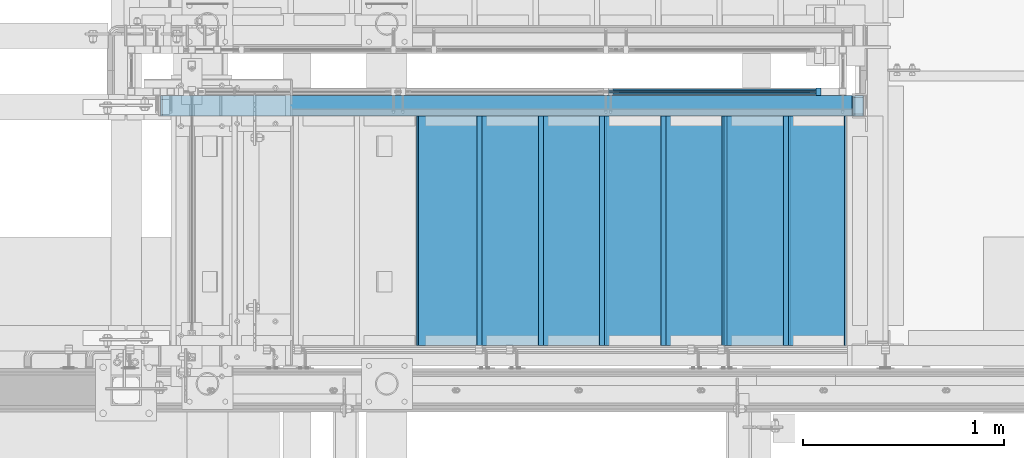
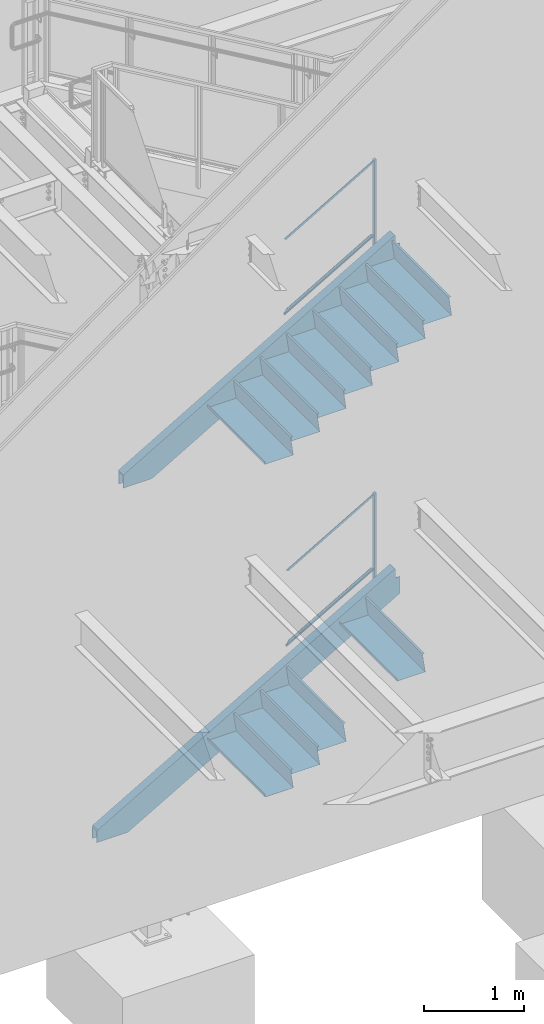
# One storey, part 784 of 1179: 15 beams, 6 members, 4 elements without a shape of their own.
"""IFC2X3 building model written with IfcOpenShell, lengths in millimetres."""

from ifc_helpers import new_model, si_unit, frame, origin_with_axes, place, context, subcontext, project, spatial, faceted_brep, material, type_object, element, aggregate, save


model = new_model("IFC2X3")

# Units and contexts
model_context = context("Model", 3, precision=1e-05, world=origin_with_axes())
body_context = subcontext(model_context, "Body", "Model", "MODEL_VIEW")
ifc_project = project(units=[si_unit("LENGTHUNIT", "METRE", prefix="MILLI"), si_unit("AREAUNIT", "SQUARE_METRE"), si_unit("VOLUMEUNIT", "CUBIC_METRE"), si_unit("MASSUNIT", "GRAM", prefix="KILO"), si_unit("TIMEUNIT", "SECOND"), si_unit("PLANEANGLEUNIT", "RADIAN"), si_unit("SOLIDANGLEUNIT", "STERADIAN"), si_unit("THERMODYNAMICTEMPERATUREUNIT", "DEGREE_CELSIUS"), si_unit("LUMINOUSINTENSITYUNIT", "LUMEN")], contexts=[model_context])

# Site, building, storey
site_placement = place(None, origin_with_axes())
site = spatial("IfcSite", under=ifc_project, at=site_placement, CompositionType="ELEMENT")
building_placement = place(site_placement, origin_with_axes())
building = spatial("IfcBuilding", under=site, at=building_placement, Name="Undefined", CompositionType="ELEMENT")
storey_placement = place(building_placement, origin_with_axes())
storey = spatial("IfcBuildingStorey", under=building, at=storey_placement, Name="Undefined", CompositionType="ELEMENT", Elevation=0.0)

# Assembly, member
assembly_1_placement = place(storey_placement, origin_with_axes())
assembly_1 = element("IfcElementAssembly", 1, at=assembly_1_placement, inside=storey, Name="GUARDRAIL", AssemblyPlace="NOTDEFINED", PredefinedType="RIGID_FRAME")
ifc_material_1 = material(Name="STEEL/A36")
member_type_1 = type_object("IfcMemberType", PredefinedType="NOTDEFINED")
member_1_placement = place(assembly_1_placement, frame((22723.4750016698, 39471.5999992249, 5909.47487240477), z_axis=(0.0, -1.0, 0.0), x_axis=(0.0, 0.0, 1.0)))
member_1 = element("IfcMember", 2, at=member_1_placement, type_object=member_type_1, material=ifc_material_1, Name="POST", context=body_context, shape_type="Brep", body=[
    faceted_brep([(0.0, 12.7000000000007, -19.0500000000029), (0.0, 12.7000000000007, 19.0500000000029), (1243.17712591994, 12.7000000000007, 19.0500000000029), (1243.17712591994, 12.7000000000007, -19.0500000000029), (0.0, -12.7000000000007, 19.0500000000029), (1257.99379259886, -12.7000000000007, 19.0500000000029), (0.0, -12.7000000000007, -19.0500000000029), (1257.99379259886, -12.7000000000007, -19.0500000000029)], [[[0, 1, 2, 3]], [[1, 4, 5, 2]], [[4, 6, 7, 5]], [[6, 0, 3, 7]], [[5, 7, 3, 2]], [[6, 4, 1, 0]]]),
])

assembly_2_placement = place(storey_placement, origin_with_axes())
assembly_2 = element("IfcElementAssembly", 3, at=assembly_2_placement, inside=storey, Name="GUARDRAIL", AssemblyPlace="NOTDEFINED", PredefinedType="RIGID_FRAME")
member_2_placement = place(assembly_2_placement, frame((22723.4748880622, 39471.5999999818, 1836.90255809336), z_axis=(0.0, -1.0, 0.0), x_axis=(0.0, 0.0, 1.0)))
member_2 = element("IfcMember", 4, at=member_2_placement, type_object=member_type_1, material=ifc_material_1, Name="POST", context=body_context, shape_type="Brep", body=[
    faceted_brep([(0.0, 12.7000000000007, -19.0500000000029), (0.0, 12.7000000000007, 19.0500000000029), (1242.88603593101, 12.7000000000007, 19.0500000000029), (1242.88603593101, 12.7000000000007, -19.0500000000029), (0.0, -12.7000000000007, 19.0500000000029), (1257.59245954642, -12.7000000000007, 19.0500000000029), (0.0, -12.7000000000007, -19.0500000000029), (1257.59245954642, -12.7000000000007, -19.0500000000029)], [[[0, 1, 2, 3]], [[1, 4, 5, 2]], [[4, 6, 7, 5]], [[6, 0, 3, 7]], [[5, 7, 3, 2]], [[6, 4, 1, 0]]]),
])

# Beam
ifc_material_2 = material(Name="STEEL/BUY-OUT")
beam_type_1 = type_object("IfcBeamType", PredefinedType="NOTDEFINED")
beam_1_placement = place(assembly_1_placement, frame((22207.4247953794, 39468.4251646336, 6827.78756354688), z_axis=(-0.86377890071706, 0.0, -0.503871025835012), x_axis=(-0.503871025835012, 0.0, 0.86377890071706)))
beam_1 = element("IfcBeam", 5, at=beam_1_placement, type_object=beam_type_1, material=ifc_material_2, Name="U-EDGE", context=body_context, shape_type="Brep", body=[
    faceted_brep([(-2.62571120401844e-09, 1.58750000000146, -551.090159790514), (22.2250002407682, 1.58750000000146, -589.784707497234), (22.2250002534201, 4.76249998393178, -589.784707519266), (5.1261577027617e-07, 4.76249998815911, -551.090160687567), (5.1261577027617e-07, 7.93749998815474, -551.090160687567), (25.400000253393, 7.93749998378189, -595.312499999403), (25.4000002406228, -1.58750000000146, -595.312499999232), (-2.62571120401844e-09, -1.58750000000146, -551.090159790514), (25.4000002718667, -1.58750000000146, 595.312499998905), (2.76122591458261e-09, -1.58750000000146, 580.723427522342), (2.76122591458261e-09, 1.58750000000146, 580.723427522342), (22.2250002718201, 1.58750000000146, 593.488867387849), (22.2250002590899, 4.76250001617154, 593.48886738054), (5.1151801017113e-07, 4.76250001247536, 580.723427814559), (5.1151801017113e-07, 7.93750001247827, 580.723427814559), (25.4000002590974, 7.93750001621811, 595.31249999873)], [[[0, 1, 2, 3, 4, 5, 6, 7]], [[7, 6, 8, 9]], [[0, 7, 9, 10]], [[1, 0, 10, 11]], [[2, 1, 11, 12]], [[3, 2, 12, 13]], [[4, 3, 13, 14]], [[5, 4, 14, 15]], [[6, 5, 15, 8]], [[14, 13, 12, 11, 10, 9, 8, 15]]]),
])

beam_2_placement = place(assembly_1_placement, frame((22181.828174335, 39468.4251646336, 5963.61748034283), z_axis=(-0.86377890071706, 0.0, -0.503871025835012), x_axis=(0.503871110270223, 0.0, -0.863778851463181)))
beam_2 = element("IfcBeam", 6, at=beam_2_placement, type_object=beam_type_1, material=ifc_material_2, Name="U-EDGE", context=body_context, shape_type="Brep", body=[
    faceted_brep([(3.39150574291125e-09, 1.58750000000146, 551.090060740255), (3.39150574291125e-09, -1.58750000000146, 551.090060740255), (22.2249999259266, -1.58750000000146, 589.784086195607), (22.2249999386131, -4.76249998396088, 589.784086217693), (-1.22384335554671e-07, -4.76249998815911, 551.090060521277), (-1.22384335554671e-07, -7.93749998815474, 551.090060521277), (25.3999999386497, -7.93749998381099, 595.312500000691), (25.3999999258431, 1.58750000000146, 595.31250000052), (25.3999999312882, -7.93750001618173, -595.312500000728), (25.3999999440939, 1.58750000000146, -595.312500000899), (-3.57522367266938e-09, 1.58750000000146, -580.72370144297), (-3.57522367266938e-09, -1.58750000000146, -580.72370144297), (22.2249999440628, -1.58750000000146, -593.488900187338), (22.2249999312971, -4.76250001613516, -593.488900180007), (-1.35833943204489e-07, -4.76250001247536, -580.723701367002), (-1.35833943204489e-07, -7.93750001247827, -580.723701367002)], [[[0, 1, 2, 3, 4, 5, 6, 7]], [[7, 6, 8, 9]], [[0, 7, 9, 10]], [[1, 0, 10, 11]], [[2, 1, 11, 12]], [[3, 2, 12, 13]], [[4, 3, 13, 14]], [[5, 4, 14, 15]], [[6, 5, 15, 8]], [[14, 13, 12, 11, 10, 9, 8, 15]]]),
])

beam_3_placement = place(assembly_2_placement, frame((22219.0901164369, 39468.4251653905, 2763.9218515972), z_axis=(-0.86540914081269, 0.0, -0.501065882891503), x_axis=(-0.501065882891504, 0.0, 0.86540914081269)))
beam_3 = element("IfcBeam", 7, at=beam_3_placement, type_object=beam_type_1, material=ifc_material_2, Name="U-EDGE", context=body_context, shape_type="Brep", body=[
    faceted_brep([(5.01850081491284e-07, 7.93750000584987, 565.654393641868), (5.01850081491284e-07, 4.76250000584696, 565.654393641868), (22.2250002528726, 4.76250000758591, 578.467765219681), (22.2250002588062, 1.58750000000146, 578.467765223097), (1.87355908565223e-09, 1.58750000000146, 565.654393353612), (1.87355908565223e-09, -1.58750000000146, 565.654393353612), (25.4000002588291, -1.58750000000146, 580.298246897597), (25.4000002528755, 7.93750000761065, 580.298246894159), (25.4000002430021, -1.58750000000146, -581.025000000453), (25.4000002489647, 7.9374999923748, -581.025000000533), (5.01226168125868e-07, 7.93749999444117, -536.968296245806), (5.01226168125868e-07, 4.76249999444553, -536.968296245806), (22.2250002489855, 4.76249999245192, -575.517911967814), (22.225000243081, 1.58750000000146, -575.51791195757), (-1.78260961547494e-09, 1.58750000000146, -536.968295373328), (-1.78260961547494e-09, -1.58750000000146, -536.968295373328)], [[[0, 1, 2, 3, 4, 5, 6, 7]], [[7, 6, 8, 9]], [[0, 7, 9, 10]], [[1, 0, 10, 11]], [[2, 1, 11, 12]], [[3, 2, 12, 13]], [[4, 3, 13, 14]], [[5, 4, 14, 15]], [[6, 5, 15, 8]], [[14, 13, 12, 11, 10, 9, 8, 15]]]),
])

beam_4_placement = place(assembly_2_placement, frame((22193.6359371502, 39468.4251653905, 1898.85141215456), z_axis=(-0.86540914081269, 0.0, -0.501065882891503), x_axis=(0.501065782098943, 0.0, -0.865409199170875)))
beam_4 = element("IfcBeam", 8, at=beam_4_placement, type_object=beam_type_1, material=ifc_material_2, Name="U-EDGE", context=body_context, shape_type="Brep", body=[
    faceted_brep([(-3.45607986673713e-10, 1.58750000000146, 536.241472034682), (-3.45607986673713e-10, -1.58750000000146, 536.241472034682), (22.2250001997436, -1.58750000000146, 574.791082474552), (22.2250002132259, -4.76249998287676, 574.791082497944), (4.30125510320067e-07, -4.76249998738058, 536.241472781338), (4.30125510320067e-07, -7.93749998737621, 536.241472781338), (25.400000213227, -7.93749998271232, 580.298169654056), (25.4000001996137, 1.58750000000146, 580.298169630441), (25.4000002140147, -7.93750001730223, -581.024999999514), (25.4000002276443, 1.58750000000146, -581.0249999997), (3.69254848919809e-10, 1.58750000000146, -566.38114146873), (3.69254848919809e-10, -1.58750000000146, -566.38114146873), (22.2250002275978, -1.58750000000146, -579.194516836025), (22.2250002140099, -4.76250001724839, -579.194516828193), (4.23933670390397e-07, -4.76250001332664, -566.381141712925), (4.23933670390397e-07, -7.93750001332955, -566.381141712925)], [[[0, 1, 2, 3, 4, 5, 6, 7]], [[7, 6, 8, 9]], [[0, 7, 9, 10]], [[1, 0, 10, 11]], [[2, 1, 11, 12]], [[3, 2, 12, 13]], [[4, 3, 13, 14]], [[5, 4, 14, 15]], [[6, 5, 15, 8]], [[14, 13, 12, 11, 10, 9, 8, 15]]]),
])

# Member
member_type_2 = type_object("IfcMemberType", PredefinedType="NOTDEFINED")
member_3_placement = place(assembly_1_placement, frame((21666.2000003427, 39471.5999992249, 5623.54470008453), z_axis=(0.0, -1.0, 0.0), x_axis=(0.863779574529786, 0.0, 0.503869870725709)))
member_3 = element("IfcMember", 9, at=member_3_placement, type_object=member_type_2, material=ifc_material_1, Name="BOTTOM_RAIL", context=body_context, shape_type="Brep", body=[
    faceted_brep([(1213.01152042107, 6.34999999947649, 12.6999999999971), (1205.60320984404, -6.35000000051605, 12.6999999999971), (1205.60320984404, -6.35000000051605, -12.6999999999971), (1213.01152042107, 6.34999999947649, -12.6999999999971), (18.4069803798266, 6.34999999998945, 12.6999999999971), (18.4069803798266, 6.34999999998945, -12.6999999999971), (10.9986698027969, -6.35000000000309, -12.6999999999971), (10.9986698027969, -6.35000000000309, 12.6999999999971)], [[[0, 1, 2, 3]], [[4, 5, 6, 7]], [[5, 4, 0, 3]], [[6, 5, 3, 2]], [[7, 6, 2, 1]], [[4, 7, 1, 0]]]),
])

aggregate(assembly_1, [beam_1, beam_2, member_3, member_1])

member_4_placement = place(assembly_2_placement, frame((21689.4832589038, 39471.5999999818, 1568.41922878821), z_axis=(0.0, -1.0, 0.0), x_axis=(0.86540914081267, 0.0, 0.501065882891537)))
member_4 = element("IfcMember", 10, at=member_4_placement, type_object=member_type_2, material=ifc_material_1, Name="BOTTOM_RAIL", context=body_context, shape_type="Brep", body=[
    faceted_brep([(1183.80237647433, 6.34999999946194, 12.6999999999971), (1176.44916466662, -6.35000000052969, 12.6999999999971), (1176.44916466662, -6.35000000052969, -12.6999999999971), (1183.80237647433, 6.34999999946194, -12.6999999999971), (18.3517455546971, 6.34999999998763, 12.6999999999971), (18.3517455546971, 6.34999999998763, -12.6999999999971), (10.9985337469952, -6.35000000000582, -12.6999999999971), (10.9985337469952, -6.35000000000582, 12.6999999999971)], [[[0, 1, 2, 3]], [[4, 5, 6, 7]], [[5, 4, 0, 3]], [[6, 5, 3, 2]], [[7, 6, 2, 1]], [[4, 7, 1, 0]]]),
])

aggregate(assembly_2, [member_4, beam_3, beam_4, member_2])

# Assembly, beams
assembly_3_placement = place(storey_placement, origin_with_axes())
assembly_3 = element("IfcElementAssembly", 11, at=assembly_3_placement, inside=storey, Name="STAIR", AssemblyPlace="NOTDEFINED", PredefinedType="RIGID_FRAME")
beam_type_2 = type_object("IfcBeamType", PredefinedType="NOTDEFINED")
beam_5_placement = place(assembly_3_placement, frame((22879.0499999978, 38779.4500001282, 6189.96000000019), z_axis=(0.0, -1.0, 0.0), x_axis=(-1.0, 0.0, 0.0)))
beam_5 = element("IfcBeam", 12, at=beam_5_placement, type_object=beam_type_2, material=ifc_material_1, Name="TREAD", context=body_context, shape_type="Brep", body=[
    faceted_brep([(0.0, -1.28999999999996, -571.5), (0.0, -1.28999999999996, 571.5), (0.0, 1.28999999999996, 571.5), (0.0, 1.28999999999996, -571.5), (22.4252350064853, 1.28999999999996, 571.5), (22.4252350064853, 1.28999999999996, -571.5), (25.4000000000015, -1.28999999999996, -571.5), (25.4000000000015, -1.28999999999996, 571.5), (-10.2319078506589, 229.89, 571.5), (-10.2319078506589, 229.89, -571.5), (-7.25714285714275, 227.31, -571.5), (-7.25714285714275, 227.31, 571.5), (319.968697988821, 229.89, 571.5), (319.968697988821, 229.89, -571.5), (317.731075852447, 227.31, -571.5), (317.731075852447, 227.31, 571.5), (325.673299218732, 189.957791390602, 571.5), (325.673299218732, 189.957791390602, -571.5), (323.119229525088, 189.592924291511, 571.5), (323.119229525088, 189.592924291511, -571.5)], [[[0, 1, 2, 3]], [[3, 2, 4, 5]], [[1, 0, 6, 7]], [[5, 4, 8, 9]], [[7, 6, 10, 11]], [[9, 8, 12, 13]], [[11, 10, 14, 15]], [[13, 12, 16, 17]], [[12, 8, 4, 2, 1, 7, 11, 15, 18, 16]], [[15, 14, 19, 18]], [[14, 10, 6, 0, 3, 5, 9, 13, 17, 19]], [[18, 19, 17, 16]]]),
])
beam_6_placement = place(assembly_3_placement, frame((22574.2500000208, 38779.4500001282, 6012.16000000019), z_axis=(0.0, -1.0, 0.0), x_axis=(-1.0, 0.0, 0.0)))
beam_6 = element("IfcBeam", 13, at=beam_6_placement, type_object=beam_type_2, material=ifc_material_1, Name="TREAD", context=body_context, shape_type="Brep", body=[
    faceted_brep([(0.0, -1.28999999999996, -571.5), (0.0, -1.28999999999996, 571.5), (0.0, 1.28999999999996, 571.5), (0.0, 1.28999999999996, -571.5), (22.4252350064853, 1.28999999999996, 571.5), (22.4252350064853, 1.28999999999996, -571.5), (25.4000000000015, -1.28999999999996, -571.5), (25.4000000000015, -1.28999999999996, 571.5), (-10.2319078506589, 229.89, 571.5), (-10.2319078506589, 229.89, -571.5), (-7.25714285714275, 227.31, -571.5), (-7.25714285714275, 227.31, 571.5), (319.968697988821, 229.89, 571.5), (319.968697988821, 229.89, -571.5), (317.731075852447, 227.31, -571.5), (317.731075852447, 227.31, 571.5), (325.673299218732, 189.957791390602, 571.5), (325.673299218732, 189.957791390602, -571.5), (323.119229525088, 189.592924291511, 571.5), (323.119229525088, 189.592924291511, -571.5)], [[[0, 1, 2, 3]], [[3, 2, 4, 5]], [[1, 0, 6, 7]], [[5, 4, 8, 9]], [[7, 6, 10, 11]], [[9, 8, 12, 13]], [[11, 10, 14, 15]], [[13, 12, 16, 17]], [[12, 8, 4, 2, 1, 7, 11, 15, 18, 16]], [[15, 14, 19, 18]], [[14, 10, 6, 0, 3, 5, 9, 13, 17, 19]], [[18, 19, 17, 16]]]),
])
beam_7_placement = place(assembly_3_placement, frame((22269.4500000437, 38779.4500001282, 5834.36000000019), z_axis=(0.0, -1.0, 0.0), x_axis=(-1.0, 0.0, 0.0)))
beam_7 = element("IfcBeam", 14, at=beam_7_placement, type_object=beam_type_2, material=ifc_material_1, Name="TREAD", context=body_context, shape_type="Brep", body=[
    faceted_brep([(0.0, -1.28999999999996, -571.5), (0.0, -1.28999999999996, 571.5), (0.0, 1.28999999999996, 571.5), (0.0, 1.28999999999996, -571.5), (22.4252350064853, 1.28999999999996, 571.5), (22.4252350064853, 1.28999999999996, -571.5), (25.4000000000015, -1.28999999999996, -571.5), (25.4000000000015, -1.28999999999996, 571.5), (-10.2319078506589, 229.89, 571.5), (-10.2319078506589, 229.89, -571.5), (-7.25714285714275, 227.31, -571.5), (-7.25714285714275, 227.31, 571.5), (319.968697988821, 229.89, 571.5), (319.968697988821, 229.89, -571.5), (317.731075852447, 227.31, -571.5), (317.731075852447, 227.31, 571.5), (325.673299218732, 189.957791390602, 571.5), (325.673299218732, 189.957791390602, -571.5), (323.119229525088, 189.592924291511, 571.5), (323.119229525088, 189.592924291511, -571.5)], [[[0, 1, 2, 3]], [[3, 2, 4, 5]], [[1, 0, 6, 7]], [[5, 4, 8, 9]], [[7, 6, 10, 11]], [[9, 8, 12, 13]], [[11, 10, 14, 15]], [[13, 12, 16, 17]], [[12, 8, 4, 2, 1, 7, 11, 15, 18, 16]], [[15, 14, 19, 18]], [[14, 10, 6, 0, 3, 5, 9, 13, 17, 19]], [[18, 19, 17, 16]]]),
])
beam_8_placement = place(assembly_3_placement, frame((21964.6500000666, 38779.4500001282, 5656.56000000019), z_axis=(0.0, -1.0, 0.0), x_axis=(-1.0, 0.0, 0.0)))
beam_8 = element("IfcBeam", 15, at=beam_8_placement, type_object=beam_type_2, material=ifc_material_1, Name="TREAD", context=body_context, shape_type="Brep", body=[
    faceted_brep([(0.0, -1.28999999999996, -571.5), (0.0, -1.28999999999996, 571.5), (0.0, 1.28999999999996, 571.5), (0.0, 1.28999999999996, -571.5), (22.4252350064853, 1.28999999999996, 571.5), (22.4252350064853, 1.28999999999996, -571.5), (25.4000000000015, -1.28999999999996, -571.5), (25.4000000000015, -1.28999999999996, 571.5), (-10.2319078506589, 229.89, 571.5), (-10.2319078506589, 229.89, -571.5), (-7.25714285714275, 227.31, -571.5), (-7.25714285714275, 227.31, 571.5), (319.968697988821, 229.89, 571.5), (319.968697988821, 229.89, -571.5), (317.731075852447, 227.31, -571.5), (317.731075852447, 227.31, 571.5), (325.673299218732, 189.957791390602, 571.5), (325.673299218732, 189.957791390602, -571.5), (323.119229525088, 189.592924291511, 571.5), (323.119229525088, 189.592924291511, -571.5)], [[[0, 1, 2, 3]], [[3, 2, 4, 5]], [[1, 0, 6, 7]], [[5, 4, 8, 9]], [[7, 6, 10, 11]], [[9, 8, 12, 13]], [[11, 10, 14, 15]], [[13, 12, 16, 17]], [[12, 8, 4, 2, 1, 7, 11, 15, 18, 16]], [[15, 14, 19, 18]], [[14, 10, 6, 0, 3, 5, 9, 13, 17, 19]], [[18, 19, 17, 16]]]),
])
beam_9_placement = place(assembly_3_placement, frame((21659.8500000895, 38779.4500001282, 5478.76000000019), z_axis=(0.0, -1.0, 0.0), x_axis=(-1.0, 0.0, 0.0)))
beam_9 = element("IfcBeam", 16, at=beam_9_placement, type_object=beam_type_2, material=ifc_material_1, Name="TREAD", context=body_context, shape_type="Brep", body=[
    faceted_brep([(0.0, -1.28999999999996, -571.5), (0.0, -1.28999999999996, 571.5), (0.0, 1.28999999999996, 571.5), (0.0, 1.28999999999996, -571.5), (22.4252350064853, 1.28999999999996, 571.5), (22.4252350064853, 1.28999999999996, -571.5), (25.4000000000015, -1.28999999999996, -571.5), (25.4000000000015, -1.28999999999996, 571.5), (-10.2319078506589, 229.89, 571.5), (-10.2319078506589, 229.89, -571.5), (-7.25714285714275, 227.31, -571.5), (-7.25714285714275, 227.31, 571.5), (319.968697988821, 229.89, 571.5), (319.968697988821, 229.89, -571.5), (317.731075852447, 227.31, -571.5), (317.731075852447, 227.31, 571.5), (325.673299218732, 189.957791390602, 571.5), (325.673299218732, 189.957791390602, -571.5), (323.119229525088, 189.592924291511, 571.5), (323.119229525088, 189.592924291511, -571.5)], [[[0, 1, 2, 3]], [[3, 2, 4, 5]], [[1, 0, 6, 7]], [[5, 4, 8, 9]], [[7, 6, 10, 11]], [[9, 8, 12, 13]], [[11, 10, 14, 15]], [[13, 12, 16, 17]], [[12, 8, 4, 2, 1, 7, 11, 15, 18, 16]], [[15, 14, 19, 18]], [[14, 10, 6, 0, 3, 5, 9, 13, 17, 19]], [[18, 19, 17, 16]]]),
])
beam_10_placement = place(assembly_3_placement, frame((21355.0500001124, 38779.4500001282, 5300.96000000019), z_axis=(0.0, -1.0, 0.0), x_axis=(-1.0, 0.0, 0.0)))
beam_10 = element("IfcBeam", 17, at=beam_10_placement, type_object=beam_type_2, material=ifc_material_1, Name="TREAD", context=body_context, shape_type="Brep", body=[
    faceted_brep([(0.0, -1.28999999999996, -571.5), (0.0, -1.28999999999996, 571.5), (0.0, 1.28999999999996, 571.5), (0.0, 1.28999999999996, -571.5), (22.4252350064853, 1.28999999999996, 571.5), (22.4252350064853, 1.28999999999996, -571.5), (25.4000000000015, -1.28999999999996, -571.5), (25.4000000000015, -1.28999999999996, 571.5), (-10.2319078506589, 229.89, 571.5), (-10.2319078506589, 229.89, -571.5), (-7.25714285714275, 227.31, -571.5), (-7.25714285714275, 227.31, 571.5), (319.968697988821, 229.89, 571.5), (319.968697988821, 229.89, -571.5), (317.731075852447, 227.31, -571.5), (317.731075852447, 227.31, 571.5), (325.673299218732, 189.957791390602, 571.5), (325.673299218732, 189.957791390602, -571.5), (323.119229525088, 189.592924291511, 571.5), (323.119229525088, 189.592924291511, -571.5)], [[[0, 1, 2, 3]], [[3, 2, 4, 5]], [[1, 0, 6, 7]], [[5, 4, 8, 9]], [[7, 6, 10, 11]], [[9, 8, 12, 13]], [[11, 10, 14, 15]], [[13, 12, 16, 17]], [[12, 8, 4, 2, 1, 7, 11, 15, 18, 16]], [[15, 14, 19, 18]], [[14, 10, 6, 0, 3, 5, 9, 13, 17, 19]], [[18, 19, 17, 16]]]),
])
beam_11_placement = place(assembly_3_placement, frame((21050.2500001353, 38779.4500001282, 5123.16000000019), z_axis=(0.0, -1.0, 0.0), x_axis=(-1.0, 0.0, 0.0)))
beam_11 = element("IfcBeam", 18, at=beam_11_placement, type_object=beam_type_2, material=ifc_material_1, Name="TREAD", context=body_context, shape_type="Brep", body=[
    faceted_brep([(0.0, -1.28999999999996, -571.5), (0.0, -1.28999999999996, 571.5), (0.0, 1.28999999999996, 571.5), (0.0, 1.28999999999996, -571.5), (22.4252350064853, 1.28999999999996, 571.5), (22.4252350064853, 1.28999999999996, -571.5), (25.4000000000015, -1.28999999999996, -571.5), (25.4000000000015, -1.28999999999996, 571.5), (-10.2319078506589, 229.89, 571.5), (-10.2319078506589, 229.89, -571.5), (-7.25714285714275, 227.31, -571.5), (-7.25714285714275, 227.31, 571.5), (319.968697988821, 229.89, 571.5), (319.968697988821, 229.89, -571.5), (317.731075852447, 227.31, -571.5), (317.731075852447, 227.31, 571.5), (325.673299218732, 189.957791390602, 571.5), (325.673299218732, 189.957791390602, -571.5), (323.119229525088, 189.592924291511, 571.5), (323.119229525088, 189.592924291511, -571.5)], [[[0, 1, 2, 3]], [[3, 2, 4, 5]], [[1, 0, 6, 7]], [[5, 4, 8, 9]], [[7, 6, 10, 11]], [[9, 8, 12, 13]], [[11, 10, 14, 15]], [[13, 12, 16, 17]], [[12, 8, 4, 2, 1, 7, 11, 15, 18, 16]], [[15, 14, 19, 18]], [[14, 10, 6, 0, 3, 5, 9, 13, 17, 19]], [[18, 19, 17, 16]]]),
])

assembly_4_placement = place(storey_placement, origin_with_axes())
assembly_4 = element("IfcElementAssembly", 19, at=assembly_4_placement, inside=storey, Name="STAIR", AssemblyPlace="NOTDEFINED", PredefinedType="RIGID_FRAME")
beam_12_placement = place(assembly_4_placement, frame((22574.2500003809, 38779.4500000251, 1939.95791607597), z_axis=(0.0, -1.0, 0.0), x_axis=(-1.0, 0.0, 0.0)))
beam_12 = element("IfcBeam", 20, at=beam_12_placement, type_object=beam_type_2, material=ifc_material_1, Name="TREAD", context=body_context, shape_type="Brep", body=[
    faceted_brep([(0.0, -1.28999999999996, -571.5), (0.0, -1.28999999999996, 571.5), (0.0, 1.28999999999996, 571.5), (0.0, 1.28999999999996, -571.5), (22.4220799334253, 1.28999999999996, 571.5), (22.4220799334253, 1.28999999999996, -571.5), (25.4000000000015, -1.28999999999996, -571.5), (25.4000000000015, -1.28999999999996, 571.5), (-10.2894642965184, 228.56708328371, 571.5), (-10.2894642965184, 228.56708328371, -571.5), (-7.31154422994223, 225.98708328371, -571.5), (-7.31154422994223, 225.98708328371, 571.5), (319.911141878769, 228.56708328371, 571.5), (319.911141878769, 228.56708328371, -571.5), (317.675890478069, 225.98708328371, -571.5), (317.675890478069, 225.98708328371, 571.5), (325.657303794516, 188.643229151176, 571.5), (325.657303794516, 188.643229151176, -571.5), (323.103618368372, 188.27568222317, 571.5), (323.103618368372, 188.27568222317, -571.5)], [[[0, 1, 2, 3]], [[3, 2, 4, 5]], [[1, 0, 6, 7]], [[5, 4, 8, 9]], [[7, 6, 10, 11]], [[9, 8, 12, 13]], [[11, 10, 14, 15]], [[13, 12, 16, 17]], [[12, 8, 4, 2, 1, 7, 11, 15, 18, 16]], [[15, 14, 19, 18]], [[14, 10, 6, 0, 3, 5, 9, 13, 17, 19]], [[18, 19, 17, 16]]]),
])
beam_13_placement = place(assembly_4_placement, frame((21659.8500003007, 38779.4500000289, 1410.52666623838), z_axis=(0.0, -1.0, 0.0), x_axis=(-1.0, 0.0, 0.0)))
beam_13 = element("IfcBeam", 21, at=beam_13_placement, type_object=beam_type_2, material=ifc_material_1, Name="TREAD", context=body_context, shape_type="Brep", body=[
    faceted_brep([(0.0, -1.28999999999996, -571.5), (0.0, -1.28999999999996, 571.5), (0.0, 1.28999999999996, 571.5), (0.0, 1.28999999999996, -571.5), (22.4220799334253, 1.28999999999996, 571.5), (22.4220799334253, 1.28999999999996, -571.5), (25.4000000000015, -1.28999999999996, -571.5), (25.4000000000015, -1.28999999999996, 571.5), (-10.2894642965184, 228.56708328371, 571.5), (-10.2894642965184, 228.56708328371, -571.5), (-7.31154422994223, 225.98708328371, -571.5), (-7.31154422994223, 225.98708328371, 571.5), (319.911141878769, 228.56708328371, 571.5), (319.911141878769, 228.56708328371, -571.5), (317.675890478069, 225.98708328371, -571.5), (317.675890478069, 225.98708328371, 571.5), (325.657303794516, 188.643229151176, 571.5), (325.657303794516, 188.643229151176, -571.5), (323.103618368372, 188.27568222317, 571.5), (323.103618368372, 188.27568222317, -571.5)], [[[0, 1, 2, 3]], [[3, 2, 4, 5]], [[1, 0, 6, 7]], [[5, 4, 8, 9]], [[7, 6, 10, 11]], [[9, 8, 12, 13]], [[11, 10, 14, 15]], [[13, 12, 16, 17]], [[12, 8, 4, 2, 1, 7, 11, 15, 18, 16]], [[15, 14, 19, 18]], [[14, 10, 6, 0, 3, 5, 9, 13, 17, 19]], [[18, 19, 17, 16]]]),
])
beam_14_placement = place(assembly_4_placement, frame((21355.0500002739, 38779.4500000302, 1234.04958295918), z_axis=(0.0, -1.0, 0.0), x_axis=(-1.0, 0.0, 0.0)))
beam_14 = element("IfcBeam", 22, at=beam_14_placement, type_object=beam_type_2, material=ifc_material_1, Name="TREAD", context=body_context, shape_type="Brep", body=[
    faceted_brep([(0.0, -1.28999999999996, -571.5), (0.0, -1.28999999999996, 571.5), (0.0, 1.28999999999996, 571.5), (0.0, 1.28999999999996, -571.5), (22.4220799334253, 1.28999999999996, 571.5), (22.4220799334253, 1.28999999999996, -571.5), (25.4000000000015, -1.28999999999996, -571.5), (25.4000000000015, -1.28999999999996, 571.5), (-10.2894642965184, 228.56708328371, 571.5), (-10.2894642965184, 228.56708328371, -571.5), (-7.31154422994223, 225.98708328371, -571.5), (-7.31154422994223, 225.98708328371, 571.5), (319.911141878769, 228.56708328371, 571.5), (319.911141878769, 228.56708328371, -571.5), (317.675890478069, 225.98708328371, -571.5), (317.675890478069, 225.98708328371, 571.5), (325.657303794516, 188.643229151176, 571.5), (325.657303794516, 188.643229151176, -571.5), (323.103618368372, 188.27568222317, 571.5), (323.103618368372, 188.27568222317, -571.5)], [[[0, 1, 2, 3]], [[3, 2, 4, 5]], [[1, 0, 6, 7]], [[5, 4, 8, 9]], [[7, 6, 10, 11]], [[9, 8, 12, 13]], [[11, 10, 14, 15]], [[13, 12, 16, 17]], [[12, 8, 4, 2, 1, 7, 11, 15, 18, 16]], [[15, 14, 19, 18]], [[14, 10, 6, 0, 3, 5, 9, 13, 17, 19]], [[18, 19, 17, 16]]]),
])
beam_15_placement = place(assembly_4_placement, frame((21050.2500002472, 38779.4500000315, 1057.57249967998), z_axis=(0.0, -1.0, 0.0), x_axis=(-1.0, 0.0, 0.0)))
beam_15 = element("IfcBeam", 23, at=beam_15_placement, type_object=beam_type_2, material=ifc_material_1, Name="TREAD", context=body_context, shape_type="Brep", body=[
    faceted_brep([(0.0, -1.28999999999996, -571.5), (0.0, -1.28999999999996, 571.5), (0.0, 1.28999999999996, 571.5), (0.0, 1.28999999999996, -571.5), (22.4220799334253, 1.28999999999996, 571.5), (22.4220799334253, 1.28999999999996, -571.5), (25.4000000000015, -1.28999999999996, -571.5), (25.4000000000015, -1.28999999999996, 571.5), (-10.2894642965184, 228.56708328371, 571.5), (-10.2894642965184, 228.56708328371, -571.5), (-7.31154422994223, 225.98708328371, -571.5), (-7.31154422994223, 225.98708328371, 571.5), (319.911141878769, 228.56708328371, 571.5), (319.911141878769, 228.56708328371, -571.5), (317.675890478069, 225.98708328371, -571.5), (317.675890478069, 225.98708328371, 571.5), (325.657303794516, 188.643229151176, 571.5), (325.657303794516, 188.643229151176, -571.5), (323.103618368372, 188.27568222317, 571.5), (323.103618368372, 188.27568222317, -571.5)], [[[0, 1, 2, 3]], [[3, 2, 4, 5]], [[1, 0, 6, 7]], [[5, 4, 8, 9]], [[7, 6, 10, 11]], [[9, 8, 12, 13]], [[11, 10, 14, 15]], [[13, 12, 16, 17]], [[12, 8, 4, 2, 1, 7, 11, 15, 18, 16]], [[15, 14, 19, 18]], [[14, 10, 6, 0, 3, 5, 9, 13, 17, 19]], [[18, 19, 17, 16]]]),
])

# Member
ifc_material_3 = material()
member_type_3 = type_object("IfcMemberType", Name="HSS12X4X3/8", PredefinedType="NOTDEFINED")
member_5_placement = place(assembly_3_placement, frame((22967.115933237, 39401.7499999818, 6110.4100955042), z_axis=(-0.503871025835012, 0.0, 0.86377890071706), x_axis=(-0.86377890071706, 0.0, -0.503871025835012)))
member_5 = element("IfcMember", 24, at=member_5_placement, type_object=member_type_3, material=ifc_material_3, Name="STAIR", ObjectType="HSS12X4X3/8", context=body_context, shape_type="Brep", body=[
    faceted_brep([(3457.27893750778, 41.2750000000015, -142.874999996869), (3440.95036609263, 41.2750000000015, -152.399999996876), (3422.04671910428, 50.8000000000029, -152.399999996896), (3709.82686019625, 50.8000000000029, 15.4717491115816), (3714.62623171734, 41.2750000000015, 7.24425508226068), (3457.27893750778, -41.2750000000015, -142.874999996869), (3714.62623171734, -41.2750000000015, 7.24425508226068), (3709.82686019625, -50.8000000000029, 15.4717491115816), (3422.04671910428, -50.8000000000029, -152.399999996896), (3440.95036609263, -41.2750000000015, -152.399999996876), (0.0, -50.8000000000029, 152.4), (0.0, 50.8000000000029, 152.4), (-3.97252887107243, 50.8000000000029, 150.082691484622), (-3.97252887107243, -50.8000000000029, 150.082691484622), (106.270257318156, 41.2750000000015, -142.874999999844), (106.270257318156, -41.2750000000015, -142.874999999844), (3635.50829711441, 41.2750000000015, 142.87500000316), (3635.50829711441, -41.2750000000015, 142.87500000316), (0.231957831809268, -41.2750000000015, 142.874999999935), (0.231957831809268, 41.2750000000015, 142.874999999935), (53.3201256041248, 41.2750000000015, 51.8667124667472), (8.06890855577149, 41.2750000000015, 25.4701691672326), (53.3201256041248, 50.8000000000029, 51.8667124667472), (8.06890855577149, 50.8000000000029, 25.4701691672326), (111.826507322767, -50.8000000000029, -152.399999999834), (111.826507322767, 50.8000000000029, -152.399999999834), (8.06890855577149, -50.8000000000029, 25.4701691672326), (8.06890855577149, -41.2750000000015, 25.4701691672326), (53.3201256041248, -50.8000000000029, 51.8667124667472), (53.3201256041248, -41.2750000000015, 51.8667124667472), (3629.9520471098, 50.8000000000029, 152.400000003153), (3629.9520471098, -50.8000000000029, 152.400000003153)], [[[0, 1, 2, 3, 4]], [[5, 6, 7, 8, 9]], [[10, 11, 12, 13]], [[14, 15, 5, 0]], [[16, 17, 18, 19]], [[14, 0, 4, 16, 19, 20, 21]], [[20, 22, 23, 21]], [[9, 8, 24, 25, 2, 1]], [[15, 14, 21, 23, 25, 24, 26, 27]], [[28, 29, 27, 26]], [[17, 6, 5, 15, 27, 29, 18]], [[5, 9, 1, 0]], [[30, 31, 7, 6, 17, 16, 4, 3]], [[31, 10, 13, 28, 26, 24, 8, 7]], [[22, 20, 19, 18, 29, 28, 13, 12]], [[25, 23, 22, 12, 11, 30, 3, 2]], [[31, 30, 11, 10]]]),
])

aggregate(assembly_3, [beam_5, beam_6, beam_7, beam_8, beam_9, beam_10, beam_11, member_5])

member_6_placement = place(assembly_4_placement, frame((22945.124402297, 39401.7499999987, 2023.93664627198), z_axis=(-0.501065882891504, 0.0, 0.86540914081269), x_axis=(-0.86540914081269, 0.0, -0.501065882891503)))
member_6 = element("IfcMember", 25, at=member_6_placement, type_object=member_type_3, material=ifc_material_3, Name="STAIR", ObjectType="HSS12X4X3/8", context=body_context, shape_type="Brep", body=[
    faceted_brep([(3748.01038360151, 41.2750000000015, -142.874999998245), (3712.54993284648, 50.8000000000029, -152.399999998257), (4022.85293415958, 50.8000000000029, 27.2632829333561), (4027.62558669414, 41.2750000000015, 19.0202608671207), (3712.54993284648, -50.8000000000029, -152.399999998257), (3748.01038360151, -41.2750000000015, -142.874999998245), (4027.62558669414, -41.2750000000015, 19.0202608671207), (4022.85293413572, -50.8000000000029, 27.2632829195391), (-24.7170790400414, -41.2750000000015, 142.874999999929), (-24.7170790400414, 41.2750000000015, 142.874999999929), (3955.91455281637, 41.2750000000015, 142.875000001726), (3955.91455281637, -41.2750000000015, 142.875000001726), (3955.9145523448, -50.8000000000029, 142.874999989372), (80.1952357095652, -41.2750000000015, -142.874999999902), (-17.3683512325224, -41.2750000000015, 25.6306253735456), (27.9682700164267, -41.2750000000015, 51.8802142498789), (80.1952357095652, 41.2750000000015, -142.874999999902), (27.9682700164267, 41.2750000000015, 51.8802142498789), (27.9682700164267, 50.8000000000029, 51.8802142498789), (-17.3683512325224, 50.8000000000029, 25.6306253735456), (-17.3683512325224, 41.2750000000015, 25.6306253735456), (85.7101445653534, 50.8000000000029, -152.399999999896), (85.7101445653534, -50.8000000000029, -152.399999999896), (-17.3683512325224, -50.8000000000029, 25.6306253735456), (27.9682700164267, -50.8000000000029, 51.8802142498789), (-29.0052698595973, -50.8000000000029, 150.281290598761), (-29.0052698595973, 50.8000000000029, 150.281290598761), (-25.3459696655373, -50.8000000000029, 152.399999999921), (-25.3459696655482, 50.8000000000029, 152.399999999921), (3939.39342387948, -50.8000000000029, 152.400000001715), (3939.39342387948, 50.8000000000029, 152.400000001715), (3955.91455270333, 50.8000000000029, 142.875000196958)], [[[0, 1, 2, 3]], [[4, 5, 6, 7]], [[5, 4, 1, 0]], [[8, 9, 10, 11]], [[11, 12, 7, 6]], [[5, 13, 14, 15, 8, 11, 6]], [[16, 13, 5, 0]], [[17, 18, 19, 20]], [[13, 16, 20, 19, 21, 22, 23, 14]], [[24, 15, 14, 23]], [[18, 17, 9, 8, 15, 24, 25, 26]], [[27, 28, 26, 25]], [[29, 30, 28, 27]], [[12, 11, 10, 31, 30, 29]], [[31, 10, 3, 2]], [[9, 17, 20, 16, 0, 3, 10]], [[21, 19, 18, 26, 28, 30, 31, 2, 1]], [[22, 21, 1, 4]], [[12, 29, 27, 25, 24, 23, 22, 4, 7]]]),
])

aggregate(assembly_4, [beam_12, beam_13, beam_14, beam_15, member_6])

save(model, "model.ifc")
